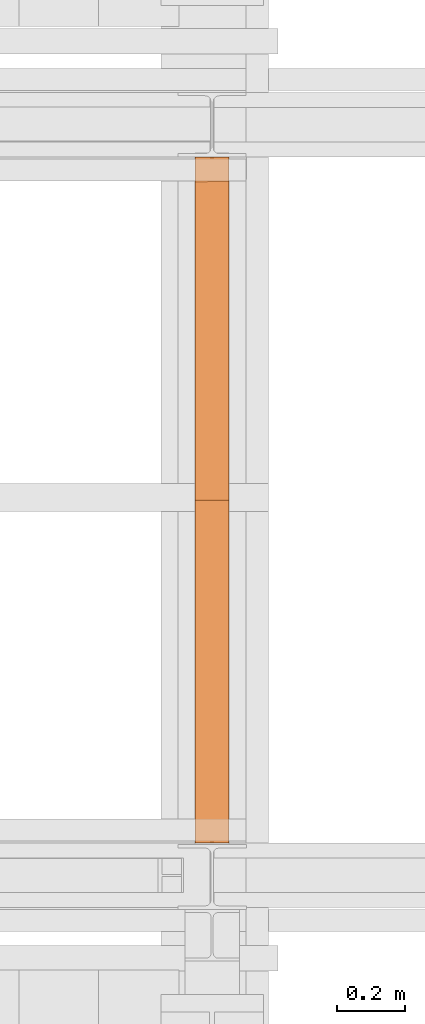
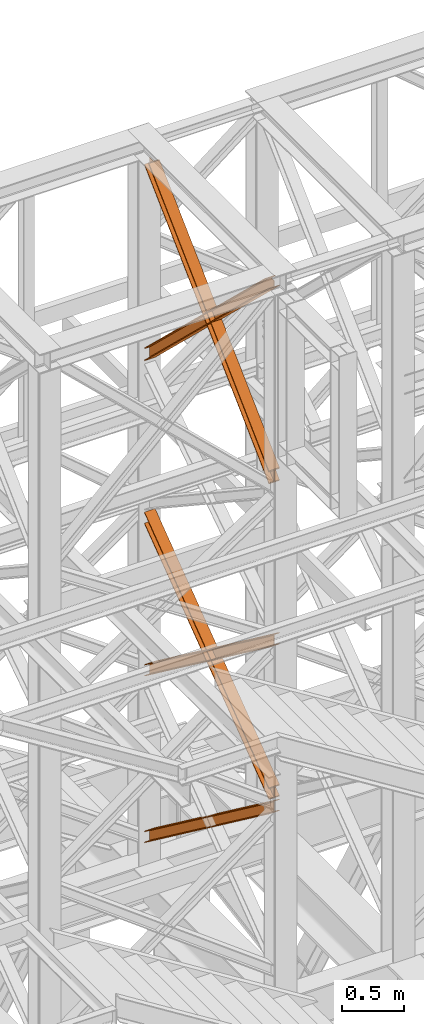
# One storey, part 100 of 208: 5 proxies.
"""IFC2X3 building model written with IfcOpenShell, lengths in millimetres."""

from ifc_helpers import new_model, entity, si_unit, converted_unit, frame, origin, origin_with_axes, place, context, subcontext, project, spatial, faceted_brep, element, save


model = new_model("IFC2X3")

# Units and contexts
model_context = context("Model", 3, precision=1e-05, world=origin())
plan_context = context("Plan", 3, precision=1e-05, world=origin())
body_context = subcontext(model_context, "Body", "Model", "MODEL_VIEW")
ifc_project = project(units=[si_unit("LENGTHUNIT", "METRE", prefix="MILLI"), converted_unit("PLANEANGLEUNIT", "DEGREE", entity("IfcPlaneAngleMeasure", 0.0174532925199433), si_unit("PLANEANGLEUNIT", "RADIAN"), dimensions=[0, 0, 0, 0, 0, 0, 0]), si_unit("AREAUNIT", "SQUARE_METRE"), si_unit("VOLUMEUNIT", "CUBIC_METRE")], contexts=[model_context, plan_context])

# Building, storey
building_placement = place(None, origin())
building = spatial("IfcBuilding", under=ifc_project, at=building_placement, CompositionType="COMPLEX")
storey_placement = place(building_placement, origin_with_axes())
storey = spatial("IfcBuildingStorey", under=building, at=storey_placement, Name="Geschoss", CompositionType="ELEMENT")

# Proxies
proxy_1_placement = place(storey_placement, frame((-1156.917323357425, -15867.5743840594, 5504.219540188055), z_axis=(0.0, 0.0, 1.0), x_axis=(1.0, 0.0, 0.0)))
element("IfcBuildingElementProxy", 1, at=proxy_1_placement, inside=storey, context=body_context, shape_type="Brep", body=[
    faceted_brep([(100.0218596475404, 0.01000000000021828, 1511.076608371926), (100.1844513161011, 2010.009987483025, 9.820176864343011), (100.1855295209296, 2010.009987483025, 0.02100513655932446), (100.022937852367, 0.01000000000021828, 1501.277436644132), (100.022937852367, 0.01000000000021828, 1501.277436644132), (100.1855295209296, 2010.009987483025, 0.02100513655932446), (0.1855301264911304, 2010.009987483025, 0.01000000000021828), (0.02293845793224136, 0.01000000000021828, 1501.266431507576), (0.02293845793224136, 0.01000000000021828, 1501.266431507576), (0.1855301264911304, 2010.009987483025, 0.01000000000021828), (0.184451921666323, 2010.009987483025, 9.809171727787543), (0.02186025310379591, 0.01000000000021828, 1511.06560323536), (0.02186025310379591, 0.01000000000021828, 1511.06560323536), (0.184451921666323, 2010.009987483025, 9.809171727787543), (47.68445163402407, 2010.009987483025, 9.814399167646116), (47.52185996546336, 0.01000000000021828, 1511.070830675226), (47.52185996546336, 0.01000000000021828, 1511.070830675226), (47.68445163402407, 2010.009987483025, 9.814399167646116), (47.67366958574507, 2010.009987483025, 107.8061164454975), (47.51107791718437, 0.01000000000021828, 1609.062547953077), (47.51107791718437, 0.01000000000021828, 1609.062547953077), (47.67366958574507, 2010.009987483025, 107.8061164454975), (0.1736698733891444, 2010.009987483025, 107.8008890056317), (0.01107820482843636, 0.01000000000021828, 1609.057320513211), (0.01107820482843636, 0.01000000000021828, 1609.057320513211), (0.1736698733891444, 2010.009987483025, 107.8008890056317), (0.172591668560699, 2010.009987483025, 117.6000607334227), (0.009999999999990905, 0.01000000000021828, 1618.856492240995), (0.009999999999990905, 0.01000000000021828, 1618.856492240995), (0.172591668560699, 2010.009987483025, 117.6000607334227), (100.1725910629973, 2010.009987483025, 117.6110658699781), (100.0099993944348, 0.01000000000021828, 1618.867497377558), (100.0099993944348, 0.01000000000021828, 1618.867497377558), (100.1725910629973, 2010.009987483025, 117.6110658699781), (100.1736692678239, 2010.009987483025, 107.8118941421981), (100.0110775992632, 0.01000000000021828, 1609.068325649774), (100.0110775992632, 0.01000000000021828, 1609.068325649774), (100.1736692678239, 2010.009987483025, 107.8118941421981), (52.67366955546436, 2010.009987483025, 107.806666702325), (52.51107788690365, 0.01000000000021828, 1609.063098209905), (52.51107788690365, 0.01000000000021828, 1609.063098209905), (52.67366955546436, 2010.009987483025, 107.806666702325), (52.68445160374517, 2010.009987483025, 9.814949424477163), (52.52185993518265, 0.01000000000021828, 1511.071380932057), (52.52185993518265, 0.01000000000021828, 1511.071380932057), (52.68445160374517, 2010.009987483025, 9.814949424477163), (100.1844513161011, 2010.009987483025, 9.820176864343011), (100.0218596475404, 0.01000000000021828, 1511.076608371926), (100.1844513161011, 2010.009987483025, 9.820176864343011), (52.68445160374517, 2010.009987483025, 9.814949424477163), (52.67366955546436, 2010.009987483025, 107.806666702325), (100.1736692678239, 2010.009987483025, 107.8118941421981), (100.1725910629973, 2010.009987483025, 117.6110658699781), (0.172591668560699, 2010.009987483025, 117.6000607334227), (0.1736698733891444, 2010.009987483025, 107.8008890056317), (47.67366958574507, 2010.009987483025, 107.8061164454975), (47.68445163402407, 2010.009987483025, 9.814399167646116), (0.184451921666323, 2010.009987483025, 9.809171727787543), (0.1855301264911304, 2010.009987483025, 0.01000000000021828), (100.1855295209296, 2010.009987483025, 0.02100513655932446), (100.022937852367, 0.01000000000021828, 1501.277436644132), (0.02293845793224136, 0.01000000000021828, 1501.266431507576), (0.02186025310379591, 0.01000000000021828, 1511.06560323536), (47.52185996546336, 0.01000000000021828, 1511.070830675226), (47.51107791718437, 0.01000000000021828, 1609.062547953077), (0.01107820482843636, 0.01000000000021828, 1609.057320513211), (0.009999999999990905, 0.01000000000021828, 1618.856492240995), (100.0099993944348, 0.01000000000021828, 1618.867497377558), (100.0110775992632, 0.01000000000021828, 1609.068325649774), (52.51107788690365, 0.01000000000021828, 1609.063098209905), (52.52185993518265, 0.01000000000021828, 1511.071380932057), (100.0218596475404, 0.01000000000021828, 1511.076608371926)], [[[0, 1, 2, 3]], [[4, 5, 6, 7]], [[8, 9, 10, 11]], [[12, 13, 14, 15]], [[16, 17, 18, 19]], [[20, 21, 22, 23]], [[24, 25, 26, 27]], [[28, 29, 30, 31]], [[32, 33, 34, 35]], [[36, 37, 38, 39]], [[40, 41, 42, 43]], [[44, 45, 46, 47]], [[48, 49, 50, 51, 52, 53, 54, 55, 56, 57, 58, 59]], [[60, 61, 62, 63, 64, 65, 66, 67, 68, 69, 70, 71]]], orient=[[False], [False], [False], [False], [False], [False], [False], [False], [False], [False], [False], [False], [False], [False]]),
])
proxy_2_placement = place(storey_placement, frame((-1157.104524643628, -15867.5743840594, 7147.441290649187), z_axis=(0.0, 0.0, 1.0), x_axis=(1.0, 0.0, 0.0)))
element("IfcBuildingElementProxy", 2, at=proxy_2_placement, inside=storey, context=body_context, shape_type="Brep", body=[
    faceted_brep([(100.021862302561, 0.01000000000021828, 1512.063556389601), (100.1844166626904, 2010.009987483025, 9.822513400360549), (100.185495108886, 2010.009987483025, 0.02100513655932446), (100.0229407487548, 0.01000000000021828, 1502.262048125804), (100.0229407487548, 0.01000000000021828, 1502.262048125804), (100.185495108886, 2010.009987483025, 0.02100513655932446), (0.1854957144512355, 2010.009987483025, 0.01000000000021828), (0.02294135431816358, 0.01000000000021828, 1502.251042989237), (0.02294135431816358, 0.01000000000021828, 1502.251042989237), (0.1854957144512355, 2010.009987483025, 0.01000000000021828), (0.1844172682556291, 2010.009987483025, 9.811508263797805), (0.02186290812619518, 0.01000000000021828, 1512.052551253039), (0.02186290812619518, 0.01000000000021828, 1512.052551253039), (0.1844172682556291, 2010.009987483025, 9.811508263797805), (47.68441698061338, 2010.009987483025, 9.816735703663653), (47.52186262048213, 0.01000000000021828, 1512.057778692908), (47.52186262048213, 0.01000000000021828, 1512.057778692908), (47.68441698061338, 2010.009987483025, 9.816735703663653), (47.6736325186846, 2010.009987483025, 107.8318183416577), (47.51107815855153, 0.01000000000021828, 1610.072861330906), (47.51107815855153, 0.01000000000021828, 1610.072861330906), (47.6736325186846, 2010.009987483025, 107.8318183416577), (0.1736328063250312, 2010.009987483025, 107.8265909017955), (0.01107844619559728, 0.01000000000021828, 1610.067633891033), (0.01107844619559728, 0.01000000000021828, 1610.067633891033), (0.1736328063250312, 2010.009987483025, 107.8265909017955), (0.1725543601312438, 2010.009987483025, 117.6280991655931), (0.009999999999990905, 0.01000000000021828, 1619.86914215483), (0.009999999999990905, 0.01000000000021828, 1619.86914215483), (0.1725543601312438, 2010.009987483025, 117.6280991655931), (100.172553754566, 2010.009987483025, 117.6391043021558), (100.0099993944348, 0.01000000000021828, 1619.880147291397), (100.0099993944348, 0.01000000000021828, 1619.880147291397), (100.172553754566, 2010.009987483025, 117.6391043021558), (100.1736322007616, 2010.009987483025, 107.8375960383546), (100.0110778406304, 0.01000000000021828, 1610.078639027603), (100.0110778406304, 0.01000000000021828, 1610.078639027603), (100.1736322007616, 2010.009987483025, 107.8375960383546), (52.67363248840388, 2010.009987483025, 107.8323685984888), (52.51107812827445, 0.01000000000021828, 1610.073411587733), (52.51107812827445, 0.01000000000021828, 1610.073411587733), (52.67363248840388, 2010.009987483025, 107.8323685984888), (52.68441695033448, 2010.009987483025, 9.817285960491063), (52.52186259020323, 0.01000000000021828, 1512.058328949732), (52.52186259020323, 0.01000000000021828, 1512.058328949732), (52.68441695033448, 2010.009987483025, 9.817285960491063), (100.1844166626904, 2010.009987483025, 9.822513400360549), (100.021862302561, 0.01000000000021828, 1512.063556389601), (100.1844166626904, 2010.009987483025, 9.822513400360549), (52.68441695033448, 2010.009987483025, 9.817285960491063), (52.67363248840388, 2010.009987483025, 107.8323685984888), (100.1736322007616, 2010.009987483025, 107.8375960383546), (100.172553754566, 2010.009987483025, 117.6391043021558), (0.1725543601312438, 2010.009987483025, 117.6280991655931), (0.1736328063250312, 2010.009987483025, 107.8265909017955), (47.6736325186846, 2010.009987483025, 107.8318183416577), (47.68441698061338, 2010.009987483025, 9.816735703663653), (0.1844172682556291, 2010.009987483025, 9.811508263797805), (0.1854957144512355, 2010.009987483025, 0.01000000000021828), (100.185495108886, 2010.009987483025, 0.02100513655932446), (100.0229407487548, 0.01000000000021828, 1502.262048125804), (0.02294135431816358, 0.01000000000021828, 1502.251042989237), (0.02186290812619518, 0.01000000000021828, 1512.052551253039), (47.52186262048213, 0.01000000000021828, 1512.057778692908), (47.51107815855153, 0.01000000000021828, 1610.072861330906), (0.01107844619559728, 0.01000000000021828, 1610.067633891033), (0.009999999999990905, 0.01000000000021828, 1619.86914215483), (100.0099993944348, 0.01000000000021828, 1619.880147291397), (100.0110778406304, 0.01000000000021828, 1610.078639027603), (52.51107812827445, 0.01000000000021828, 1610.073411587733), (52.52186259020323, 0.01000000000021828, 1512.058328949732), (100.021862302561, 0.01000000000021828, 1512.063556389601)], [[[0, 1, 2, 3]], [[4, 5, 6, 7]], [[8, 9, 10, 11]], [[12, 13, 14, 15]], [[16, 17, 18, 19]], [[20, 21, 22, 23]], [[24, 25, 26, 27]], [[28, 29, 30, 31]], [[32, 33, 34, 35]], [[36, 37, 38, 39]], [[40, 41, 42, 43]], [[44, 45, 46, 47]], [[48, 49, 50, 51, 52, 53, 54, 55, 56, 57, 58, 59]], [[60, 61, 62, 63, 64, 65, 66, 67, 68, 69, 70, 71]]], orient=[[False], [False], [False], [False], [False], [False], [False], [False], [False], [False], [False], [False], [False], [False]]),
])
proxy_3_placement = place(storey_placement, frame((-1157.104352404574, -15867.5743840594, 7147.394064575148), z_axis=(0.0, 0.0, 1.0), x_axis=(1.0, 0.0, 0.0)))
element("IfcBuildingElementProxy", 3, at=proxy_3_placement, inside=storey, context=body_context, shape_type="Brep", body=[
    faceted_brep([(100.0229386519511, 2010.009987483025, 1501.524522111415), (100.1855729074957, 0.01000000000021828, 0.02100513656296243), (100.1844946360359, 0.01000000000021828, 9.82075546136366), (100.0218603804913, 2010.009987483025, 1511.324272436212), (0.02293925751632742, 2010.009987483025, 1501.513516974852), (0.1855735130591256, 0.01000000000021828, 0.01000000000021828), (100.1855729074957, 0.01000000000021828, 0.02100513656296243), (100.0229386519511, 2010.009987483025, 1501.524522111415), (0.02186098605466214, 2010.009987483025, 1511.313267299649), (0.1844952415992793, 0.01000000000021828, 9.809750324800916), (0.1855735130591256, 0.01000000000021828, 0.01000000000021828), (0.02293925751632742, 2010.009987483025, 1501.513516974852), (47.52186069841241, 2010.009987483025, 1511.318494739518), (47.68449495395521, 0.01000000000021828, 9.814977764666764), (0.1844952415992793, 0.01000000000021828, 9.809750324800916), (0.02186098605466214, 2010.009987483025, 1511.313267299649), (47.51107798381395, 2010.009987483025, 1609.315997987507), (47.67371223936038, 0.01000000000021828, 107.8124810126556), (47.68449495395521, 0.01000000000021828, 9.814977764666764), (47.52186069841241, 2010.009987483025, 1511.318494739518), (0.0110782714598372, 2010.009987483025, 1609.310770547641), (0.1737125270026354, 0.01000000000021828, 107.8072535727861), (47.67371223936038, 0.01000000000021828, 107.8124810126556), (47.51107798381395, 2010.009987483025, 1609.315997987507), (0.009999999999990905, 2010.009987483025, 1619.110520872438), (0.1726342555446081, 0.01000000000021828, 117.6070038975868), (0.1737125270026354, 0.01000000000021828, 107.8072535727861), (0.0110782714598372, 2010.009987483025, 1609.310770547641), (100.0099993944348, 2010.009987483025, 1619.121526009001), (100.1726336499776, 0.01000000000021828, 117.6180090341495), (0.1726342555446081, 0.01000000000021828, 117.6070038975868), (0.009999999999990905, 2010.009987483025, 1619.110520872438), (100.0110776658946, 2010.009987483025, 1609.321775684197), (100.1737119214374, 0.01000000000021828, 107.8182587093452), (100.1726336499776, 0.01000000000021828, 117.6180090341495), (100.0099993944348, 2010.009987483025, 1619.121526009001), (52.51107795353687, 2010.009987483025, 1609.316548244331), (52.67371220908331, 0.01000000000021828, 107.8130312694793), (100.1737119214374, 0.01000000000021828, 107.8182587093452), (100.0110776658946, 2010.009987483025, 1609.321775684197), (52.52186066813351, 2010.009987483025, 1511.319044996339), (52.68449492367995, 0.01000000000021828, 9.815528021497812), (52.67371220908331, 0.01000000000021828, 107.8130312694793), (52.51107795353687, 2010.009987483025, 1609.316548244331), (100.0218603804913, 2010.009987483025, 1511.324272436212), (100.1844946360359, 0.01000000000021828, 9.82075546136366), (52.68449492367995, 0.01000000000021828, 9.815528021497812), (52.52186066813351, 2010.009987483025, 1511.319044996339), (100.1855729074957, 0.01000000000021828, 0.02100513656296243), (0.1855735130591256, 0.01000000000021828, 0.01000000000021828), (0.1844952415992793, 0.01000000000021828, 9.809750324800916), (47.68449495395521, 0.01000000000021828, 9.814977764666764), (47.67371223936038, 0.01000000000021828, 107.8124810126556), (0.1737125270026354, 0.01000000000021828, 107.8072535727861), (0.1726342555446081, 0.01000000000021828, 117.6070038975868), (100.1726336499776, 0.01000000000021828, 117.6180090341495), (100.1737119214374, 0.01000000000021828, 107.8182587093452), (52.67371220908331, 0.01000000000021828, 107.8130312694793), (52.68449492367995, 0.01000000000021828, 9.815528021497812), (100.1844946360359, 0.01000000000021828, 9.82075546136366), (100.0218603804913, 2010.009987483025, 1511.324272436212), (52.52186066813351, 2010.009987483025, 1511.319044996339), (52.51107795353687, 2010.009987483025, 1609.316548244331), (100.0110776658946, 2010.009987483025, 1609.321775684197), (100.0099993944348, 2010.009987483025, 1619.121526009001), (0.009999999999990905, 2010.009987483025, 1619.110520872438), (0.0110782714598372, 2010.009987483025, 1609.310770547641), (47.51107798381395, 2010.009987483025, 1609.315997987507), (47.52186069841241, 2010.009987483025, 1511.318494739518), (0.02186098605466214, 2010.009987483025, 1511.313267299649), (0.02293925751632742, 2010.009987483025, 1501.513516974852), (100.0229386519511, 2010.009987483025, 1501.524522111415)], [[[0, 1, 2, 3]], [[4, 5, 6, 7]], [[8, 9, 10, 11]], [[12, 13, 14, 15]], [[16, 17, 18, 19]], [[20, 21, 22, 23]], [[24, 25, 26, 27]], [[28, 29, 30, 31]], [[32, 33, 34, 35]], [[36, 37, 38, 39]], [[40, 41, 42, 43]], [[44, 45, 46, 47]], [[48, 49, 50, 51, 52, 53, 54, 55, 56, 57, 58, 59]], [[60, 61, 62, 63, 64, 65, 66, 67, 68, 69, 70, 71]]], orient=[[False], [False], [False], [False], [False], [False], [False], [False], [False], [False], [False], [False], [False], [False]]),
])
proxy_4_placement = place(storey_placement, frame((-1157.290733926031, -15867.57439014891, 10257.71351554296), z_axis=(0.0, 0.0, 1.0), x_axis=(1.0, 0.0, 0.0)))
element("IfcBuildingElementProxy", 4, at=proxy_4_placement, inside=storey, context=body_context, shape_type="Brep", body=[
    faceted_brep([(100.0212045496899, 2010.009993572538, 119.6472293306997), (100.1463438185763, 56.72628223557149, 1992.286543150845), (100.146635060966, 68.07077152448983, 1992.286543150845), (100.0222231921614, 2010.009993572536, 130.5233411127829), (100.0222231921614, 2010.009993572536, 130.5233411127829), (100.146635060966, 68.07077152448983, 1992.286543150845), (0.1466348943756657, 68.08252523311057, 1992.286543150842), (0.02222377857810898, 2010.009993572536, 130.5346095510231), (0.02222377857810898, 2010.009993572536, 130.5346095510231), (0.1466348943756657, 68.08252523311057, 1992.286543150842), (0.1463436519823063, 56.73803594420861, 1992.286543150842), (0.02120513611203023, 2010.009993572536, 119.6584977689327), (0.02120513611203023, 2010.009993572536, 119.6584977689327), (0.1463436519823063, 56.73803594420861, 1992.286543150842), (47.6463437311138, 56.73245293260334, 1992.286543150845), (47.52120485756109, 2010.009993572536, 119.6531452607651), (47.52120485756109, 2010.009993572536, 119.6531452607651), (47.6463437311138, 56.73245293260334, 1992.286543150845), (47.64488761591906, 0.01000608951108006, 1992.286543150845), (47.63979748861652, 0.01000608951108006, 1937.905972056111), (47.51101837541842, 2010.009993572536, 10.89202766673589), (47.51101837541842, 2010.009993572536, 10.89202766673589), (47.63979748861652, 0.01000608951108006, 1937.905972056111), (0.1397977671692843, 0.01000608951108006, 1937.911324564264), (0.01101865397117763, 2010.009993572536, 10.89738017488162), (0.01101865397117763, 2010.009993572536, 10.89738017488162), (0.1397977671692843, 0.01000608951108006, 1937.911324564264), (0.1387797399163446, 0.01000608951108006, 1927.035210352397), (0.009999999999990905, 2010.009993572536, 0.02126843821861257), (0.009999999999990905, 2010.009993572536, 0.02126843821861257), (0.1387797399163446, 0.01000608951108006, 1927.035210352397), (100.138779153496, 0.01000608951108006, 1927.023941914182), (100.009999413576, 2010.009993572536, 0.01000000000021828), (100.009999413576, 2010.009993572536, 0.01000000000021828), (100.138779153496, 0.01000608951108006, 1927.023941914182), (100.1397971807453, 0.01000608951108006, 1937.900056126053), (100.0110180675508, 2010.009993572536, 10.88611173667414), (100.0110180675508, 2010.009993572536, 10.88611173667414), (100.1397971807453, 0.01000608951108006, 1937.900056126053), (52.63979745929805, 0.01000608951108006, 1937.905408634202), (52.51101834609813, 2010.009993572536, 10.89146424482351), (52.51101834609813, 2010.009993572536, 10.89146424482351), (52.63979745929805, 0.01000608951108006, 1937.905408634202), (52.64488763917848, 0.01000000000021828, 1992.286543150845), (52.64634373944296, 56.73186524717494, 1992.286543150845), (52.52120482823898, 2010.009993572536, 119.65258183886), (52.52120482823898, 2010.009993572536, 119.65258183886), (52.64634373944296, 56.73186524717494, 1992.286543150845), (100.1463438185763, 56.72628223557149, 1992.286543150845), (100.0212045496899, 2010.009993572538, 119.6472293306997), (100.1463438185763, 56.72628223557149, 1992.286543150845), (52.64634373944296, 56.73186524717494, 1992.286543150845), (52.64488763917848, 0.01000000000021828, 1992.286543150845), (47.64488761591906, 0.01000608951108006, 1992.286543150845), (47.6463437311138, 56.73245293260334, 1992.286543150845), (0.1463436519823063, 56.73803594420861, 1992.286543150842), (0.1466348943756657, 68.08252523311057, 1992.286543150842), (100.146635060966, 68.07077152448983, 1992.286543150845), (47.64488761591906, 0.01000608951108006, 1992.286543150845), (52.64488763917848, 0.01000000000021828, 1992.286543150845), (52.63979745929805, 0.01000608951108006, 1937.905408634202), (100.1397971807453, 0.01000608951108006, 1937.900056126053), (100.138779153496, 0.01000608951108006, 1927.023941914182), (0.1387797399163446, 0.01000608951108006, 1927.035210352397), (0.1397977671692843, 0.01000608951108006, 1937.911324564264), (47.63979748861652, 0.01000608951108006, 1937.905972056111), (100.0222231921614, 2010.009993572536, 130.5233411127829), (0.02222377857810898, 2010.009993572536, 130.5346095510231), (0.02120513611203023, 2010.009993572536, 119.6584977689327), (47.52120485756109, 2010.009993572536, 119.6531452607651), (47.51101837541842, 2010.009993572536, 10.89202766673589), (0.01101865397117763, 2010.009993572536, 10.89738017488162), (0.009999999999990905, 2010.009993572536, 0.02126843821861257), (100.009999413576, 2010.009993572536, 0.01000000000021828), (100.0110180675508, 2010.009993572536, 10.88611173667414), (52.51101834609813, 2010.009993572536, 10.89146424482351), (52.52120482823898, 2010.009993572536, 119.65258183886), (100.0212045496899, 2010.009993572538, 119.6472293306997)], [[[0, 1, 2, 3]], [[4, 5, 6, 7]], [[8, 9, 10, 11]], [[12, 13, 14, 15]], [[16, 17, 18, 19, 20]], [[21, 22, 23, 24]], [[25, 26, 27, 28]], [[29, 30, 31, 32]], [[33, 34, 35, 36]], [[37, 38, 39, 40]], [[41, 42, 43, 44, 45]], [[46, 47, 48, 49]], [[50, 51, 52, 53, 54, 55, 56, 57]], [[58, 59, 60, 61, 62, 63, 64, 65]], [[66, 67, 68, 69, 70, 71, 72, 73, 74, 75, 76, 77]]], orient=[[False], [False], [False], [False], [False], [False], [False], [False], [False], [False], [False], [False], [False], [False], [False]]),
])
proxy_5_placement = place(storey_placement, frame((-1157.270962546283, -15867.5743840594, 10261.20680675583), z_axis=(0.0, 0.0, 1.0), x_axis=(1.0, 0.0, 0.0)))
element("IfcBuildingElementProxy", 5, at=proxy_5_placement, inside=storey, context=body_context, shape_type="Brep", body=[
    faceted_brep([(100.0219376352104, 0.01000000000021828, 130.5376928144524), (100.124867399614, 1937.888230286315, 1988.793251937981), (100.1244756427457, 1949.231612164787, 1988.793251937985), (100.0209427866555, 0.01000000000021828, 119.6603850577285), (0.02193825011977424, 0.01000000000021828, 130.5496157990219), (0.1248673541028893, 1937.875796424816, 1988.793251937981), (100.124867399614, 1937.888230286315, 1988.793251937981), (100.0219376352104, 0.01000000000021828, 130.5376928144524), (0.02094340156668295, 0.01000000000021828, 119.6723080422798), (0.1244755972309122, 1949.21917830328, 1988.793251937981), (0.1248673541028893, 1937.875796424816, 1988.793251937981), (0.02193825011977424, 0.01000000000021828, 130.5496157990219), (47.52094310948428, 0.01000000000021828, 119.6666446246109), (47.6244756188496, 1949.225084387492, 1988.793251937981), (0.1244755972309122, 1949.21917830328, 1988.793251937981), (0.02094340156668295, 0.01000000000021828, 119.6723080422798), (47.51099456772113, 0.01000000000021828, 10.89356727918312), (47.61776178021296, 2010.009987483025, 1938.307550640491), (47.62237652174531, 2010.009987483025, 1988.793251937981), (47.6244756188496, 1949.225084387492, 1988.793251937981), (47.52094310948428, 0.01000000000021828, 119.6666446246109), (0.01099485980716963, 0.01000000000021828, 10.899230696823), (0.1177620722971824, 2010.009987483025, 1938.313214058149), (47.61776178021296, 2010.009987483025, 1938.307550640491), (47.51099456772113, 0.01000000000021828, 10.89356727918312), (0.009999999999990905, 0.01000000000021828, 0.02192298452973773), (0.116767825262059, 2010.009987483025, 1927.43590392548), (0.1177620722971824, 2010.009987483025, 1938.313214058149), (0.01099485980716963, 0.01000000000021828, 10.899230696823), (100.0099993850834, 0.01000000000021828, 0.01000000000021828), (100.1167672103491, 2010.009987483025, 1927.42398094095), (0.116767825262059, 2010.009987483025, 1927.43590392548), (0.009999999999990905, 0.01000000000021828, 0.02192298452973773), (100.0109942448942, 0.01000000000021828, 10.88730771230075), (100.1177614573787, 2010.009987483025, 1938.301291073616), (100.1167672103491, 2010.009987483025, 1927.42398094095), (100.0099993850834, 0.01000000000021828, 0.01000000000021828), (52.51099453697111, 0.01000000000021828, 10.89297112994063), (52.61776174946658, 2010.009987483025, 1938.306954491263), (100.1177614573787, 2010.009987483025, 1938.301291073616), (100.0109942448942, 0.01000000000021828, 10.88730771230075), (52.52094307873608, 0.01000000000021828, 119.6660484753793), (52.62447562112516, 1949.225706080566, 1988.793251937981), (52.6223765454904, 2010.009987483025, 1988.793251937981), (52.61776174946658, 2010.009987483025, 1938.306954491263), (52.51099453697111, 0.01000000000021828, 10.89297112994063), (100.0209427866555, 0.01000000000021828, 119.6603850577285), (100.1244756427457, 1949.231612164787, 1988.793251937985), (52.62447562112516, 1949.225706080566, 1988.793251937981), (52.52094307873608, 0.01000000000021828, 119.6660484753793), (100.124867399614, 1937.888230286315, 1988.793251937981), (0.1248673541028893, 1937.875796424816, 1988.793251937981), (0.1244755972309122, 1949.21917830328, 1988.793251937981), (47.6244756188496, 1949.225084387492, 1988.793251937981), (47.62237652174531, 2010.009987483025, 1988.793251937981), (52.6223765454904, 2010.009987483025, 1988.793251937981), (52.62447562112516, 1949.225706080566, 1988.793251937981), (100.1244756427457, 1949.231612164787, 1988.793251937985), (47.62237652174531, 2010.009987483025, 1988.793251937981), (47.61776178021296, 2010.009987483025, 1938.307550640491), (0.1177620722971824, 2010.009987483025, 1938.313214058149), (0.116767825262059, 2010.009987483025, 1927.43590392548), (100.1167672103491, 2010.009987483025, 1927.42398094095), (100.1177614573787, 2010.009987483025, 1938.301291073616), (52.61776174946658, 2010.009987483025, 1938.306954491263), (52.6223765454904, 2010.009987483025, 1988.793251937981), (100.0209427866555, 0.01000000000021828, 119.6603850577285), (52.52094307873608, 0.01000000000021828, 119.6660484753793), (52.51099453697111, 0.01000000000021828, 10.89297112994063), (100.0109942448942, 0.01000000000021828, 10.88730771230075), (100.0099993850834, 0.01000000000021828, 0.01000000000021828), (0.009999999999990905, 0.01000000000021828, 0.02192298452973773), (0.01099485980716963, 0.01000000000021828, 10.899230696823), (47.51099456772113, 0.01000000000021828, 10.89356727918312), (47.52094310948428, 0.01000000000021828, 119.6666446246109), (0.02094340156668295, 0.01000000000021828, 119.6723080422798), (0.02193825011977424, 0.01000000000021828, 130.5496157990219), (100.0219376352104, 0.01000000000021828, 130.5376928144524)], [[[0, 1, 2, 3]], [[4, 5, 6, 7]], [[8, 9, 10, 11]], [[12, 13, 14, 15]], [[16, 17, 18, 19, 20]], [[21, 22, 23, 24]], [[25, 26, 27, 28]], [[29, 30, 31, 32]], [[33, 34, 35, 36]], [[37, 38, 39, 40]], [[41, 42, 43, 44, 45]], [[46, 47, 48, 49]], [[50, 51, 52, 53, 54, 55, 56, 57]], [[58, 59, 60, 61, 62, 63, 64, 65]], [[66, 67, 68, 69, 70, 71, 72, 73, 74, 75, 76, 77]]], orient=[[False], [False], [False], [False], [False], [False], [False], [False], [False], [False], [False], [False], [False], [False], [False]]),
])

save(model, "model.ifc")
